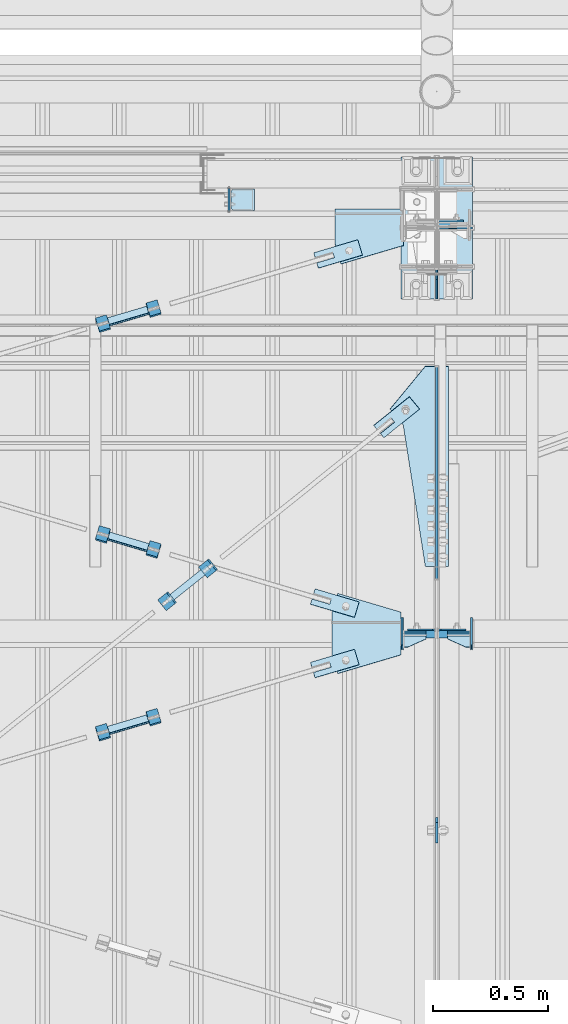
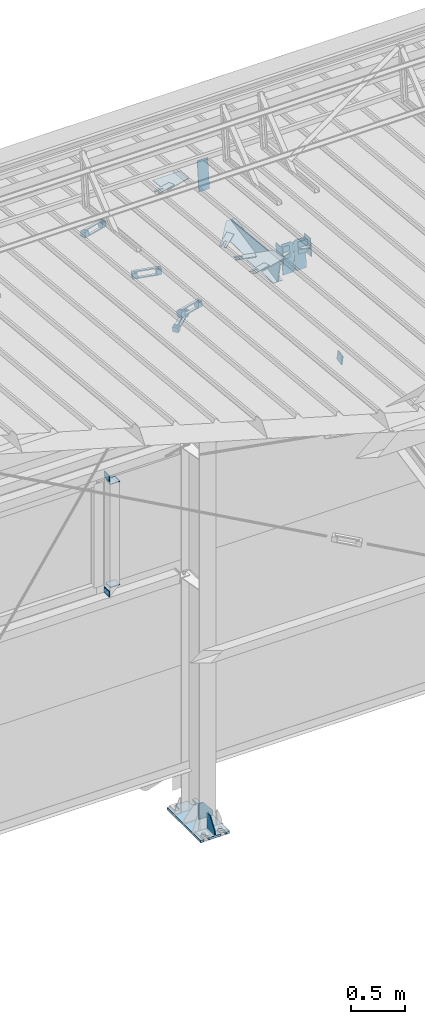
# One storey, part 164 of 709: 41 plates, 7 openings, 17 elements without a shape of their own.
"""IFC4 building model written with IfcOpenShell, lengths in millimetres."""

from ifc_helpers import new_model, si_unit, direction, frame, origin_with_axes, place, context, subcontext, project, spatial, line, arc, indexed_curve, outline, extrude, material, element, aggregate, save


model = new_model("IFC4")

# Units and contexts
model_context = context("Model", 3, precision=0.2, world=origin_with_axes(), true_north=direction((0.0, 1.0)))
body_context = subcontext(model_context, "Body", "Model", "MODEL_VIEW")
ifc_project = project(units=[si_unit("LENGTHUNIT", "METRE", prefix="MILLI"), si_unit("AREAUNIT", "SQUARE_METRE"), si_unit("VOLUMEUNIT", "CUBIC_METRE"), si_unit("MASSUNIT", "GRAM", prefix="KILO"), si_unit("TIMEUNIT", "SECOND"), si_unit("PLANEANGLEUNIT", "RADIAN"), si_unit("SOLIDANGLEUNIT", "STERADIAN"), si_unit("THERMODYNAMICTEMPERATUREUNIT", "DEGREE_CELSIUS"), si_unit("LUMINOUSINTENSITYUNIT", "LUMEN")], contexts=[model_context])

# Site, building, storey
site_placement = place(None, origin_with_axes())
site = spatial("IfcSite", under=ifc_project, at=site_placement, CompositionType="ELEMENT")
building_placement = place(site_placement, origin_with_axes())
building = spatial("IfcBuilding", under=site, at=building_placement, Name="Undefined", CompositionType="ELEMENT")
storey_placement = place(building_placement, origin_with_axes())
storey = spatial("IfcBuildingStorey", under=building, at=storey_placement, Name="Undefined", CompositionType="ELEMENT", Elevation=0.0)

# Assembly, plates, voiding features
assembly_1_placement = place(storey_placement, frame((46000.0, 21827.0, -200.0), z_axis=(-1.0, 0.0, 0.0), x_axis=(0.0, 0.0, 1.0)))
assembly_1 = element("IfcElementAssembly", 1, at=assembly_1_placement, inside=storey)
ifc_material_1 = material(Name="C355-6", Category="STEEL")
plate_1_placement = place(assembly_1_placement, frame((7434.21546, 30.02526, -3.0), z_axis=(-0.099503719, 0.9950371902, 0.0), x_axis=(0.0, 0.0, -1.0)))
plate_1 = element("IfcPlate", 2, at=plate_1_placement, material=ifc_material_1, ObjectType="581", context=body_context, shape_type="SolidModel", body=[
    extrude(outline(indexed_curve([(0.0, 0.0), (114.0, 0.0), (114.0, 333.33554), (0.0, 333.33554)], segments=[line(1, 2, 3, 4, 1)])), frame((0.0, 0.0, 4.0), z_axis=(0.0, 0.0, 1.0), x_axis=(1.0, 0.0, 0.0)), (0.0, 0.0, -1.0), 8.0),
])
plate_2_placement = place(assembly_1_placement, frame((25.0, 0.0, -3.0), z_axis=(0.0, -1.0, 0.0), x_axis=(0.0, 0.0, -1.0)))
plate_2 = element("IfcPlate", 3, at=plate_2_placement, material=ifc_material_1, ObjectType="417", context=body_context, shape_type="SolidModel", body=[
    extrude(outline(indexed_curve([(0.0, 0.0), (152.0, 0.0), (152.0, 50.0), (50.0, 175.0), (0.0, 175.0)], segments=[line(1, 2, 3, 4, 5, 1)])), frame((0.0, 0.0, 4.0), z_axis=(0.0, 0.0, 1.0), x_axis=(1.0, 0.0, 0.0)), (0.0, 0.0, -1.0), 8.0),
])
plate_3_placement = place(assembly_1_placement, frame((12.5, -308.0, 155.0), z_axis=(1.0, 0.0, 0.0), x_axis=(0.0, 0.0, -1.0)))
plate_3 = element("IfcPlate", 4, at=plate_3_placement, material=ifc_material_1, ObjectType="416", context=body_context, shape_type="SolidModel", body=[
    extrude(outline(indexed_curve([(0.0, 0.0), (310.0, 0.0), (310.0, 616.0), (0.0, 616.0)], segments=[line(1, 2, 3, 4, 1)])), frame((0.0, 0.0, 12.5), z_axis=(0.0, 0.0, 1.0), x_axis=(1.0, 0.0, 0.0)), (0.0, 0.0, -1.0), 25.0),
])
voiding_feature_1_placement = place(plate_3_placement, frame((40.0, 616.0, 0.0), z_axis=(0.0, 0.0, -1.0), x_axis=(1.0, 0.0, 0.0)))
element("IfcVoidingFeature", 5, at=voiding_feature_1_placement, cuts=plate_3, PredefinedType="HOLE", context=body_context, shape_type="SolidModel", body=[
    extrude(outline(indexed_curve([(0.0, 0.0), (50.0, 0.0), (50.0, 60.0), (42.67767, 77.67767), (25.0, 85.0), (25.0, 85.0), (7.32233, 77.67767), (0.0, 60.0)], segments=[line(1, 2, 3), arc(3, 4, 5), line(5, 6), arc(6, 7, 8), line(8, 1)])), frame((0.0, 0.0, 12.5), z_axis=(0.0, 0.0, 1.0), x_axis=(1.0, 0.0, 0.0)), (0.0, 0.0, -1.0), 25.0),
])
voiding_feature_2_placement = place(plate_3_placement, frame((40.0, 0.0, 0.0), z_axis=(0.0, 0.0, 1.0), x_axis=(1.0, 0.0, 0.0)))
element("IfcVoidingFeature", 6, at=voiding_feature_2_placement, cuts=plate_3, PredefinedType="HOLE", context=body_context, shape_type="SolidModel", body=[
    extrude(outline(indexed_curve([(0.0, 0.0), (50.0, 0.0), (50.0, 60.0), (42.67767, 77.67767), (25.0, 85.0), (25.0, 85.0), (7.32233, 77.67767), (0.0, 60.0)], segments=[line(1, 2, 3), arc(3, 4, 5), line(5, 6), arc(6, 7, 8), line(8, 1)])), frame((0.0, 0.0, 12.5), z_axis=(0.0, 0.0, 1.0), x_axis=(1.0, 0.0, 0.0)), (0.0, 0.0, -1.0), 25.0),
])
voiding_feature_3_placement = place(plate_3_placement, frame((270.0, 616.0, 0.0), z_axis=(0.0, 0.0, 1.0), x_axis=(-1.0, 0.0, 0.0)))
element("IfcVoidingFeature", 7, at=voiding_feature_3_placement, cuts=plate_3, PredefinedType="HOLE", context=body_context, shape_type="SolidModel", body=[
    extrude(outline(indexed_curve([(0.0, 0.0), (50.0, 0.0), (50.0, 60.0), (42.67767, 77.67767), (25.0, 85.0), (25.0, 85.0), (7.32233, 77.67767), (0.0, 60.0)], segments=[line(1, 2, 3), arc(3, 4, 5), line(5, 6), arc(6, 7, 8), line(8, 1)])), frame((0.0, 0.0, 12.5), z_axis=(0.0, 0.0, 1.0), x_axis=(1.0, 0.0, 0.0)), (0.0, 0.0, -1.0), 25.0),
])
voiding_feature_4_placement = place(plate_3_placement, frame((270.0, 0.0, 0.0), z_axis=(0.0, 0.0, -1.0), x_axis=(-1.0, 0.0, 0.0)))
element("IfcVoidingFeature", 8, at=voiding_feature_4_placement, cuts=plate_3, PredefinedType="HOLE", context=body_context, shape_type="SolidModel", body=[
    extrude(outline(indexed_curve([(0.0, 0.0), (50.0, 0.0), (50.0, 60.0), (42.67767, 77.67767), (25.0, 85.0), (25.0, 85.0), (7.32233, 77.67767), (0.0, 60.0)], segments=[line(1, 2, 3), arc(3, 4, 5), line(5, 6), arc(6, 7, 8), line(8, 1)])), frame((0.0, 0.0, 12.5), z_axis=(0.0, 0.0, 1.0), x_axis=(1.0, 0.0, 0.0)), (0.0, 0.0, -1.0), 25.0),
])
plate_4_placement = place(assembly_1_placement, frame((25.0, -173.0, 0.0), z_axis=(0.0, 0.0, 1.0), x_axis=(0.0, -1.0, 0.0)))
plate_4 = element("IfcPlate", 9, at=plate_4_placement, material=ifc_material_1, ObjectType="418", context=body_context, shape_type="SolidModel", body=[
    extrude(outline(indexed_curve([(0.0, 0.0), (135.0, 0.0), (135.0, 50.0), (50.0, 175.0), (0.0, 175.0)], segments=[line(1, 2, 3, 4, 5, 1)])), frame((0.0, 0.0, 4.0), z_axis=(0.0, 0.0, 1.0), x_axis=(1.0, 0.0, 0.0)), (0.0, 0.0, -1.0), 8.0),
])
aggregate(assembly_1, [plate_1, plate_2, plate_3, plate_4])

# Assembly, plates
assembly_2_placement = place(storey_placement, frame((46000.0, 21654.0, 7089.70002), z_axis=(-1.0, 0.0, 0.0), x_axis=(0.0, -0.9950371902, 0.099503719)))
assembly_2 = element("IfcElementAssembly", 10, at=assembly_2_placement, inside=storey)
plate_5_placement = place(assembly_2_placement, frame((1597.88359, 163.0, -127.0), z_axis=(1.0, 0.0, 0.0), x_axis=(0.0, 0.0, 1.0)))
plate_5 = element("IfcPlate", 11, at=plate_5_placement, material=ifc_material_1, ObjectType="585", context=body_context, shape_type="SolidModel", body=[
    extrude(outline(indexed_curve([(0.0, 0.0), (108.0, 0.0), (123.0, 15.0), (123.0, 311.0), (108.0, 326.0), (0.0, 326.0)], segments=[line(1, 2, 3, 4, 5, 6, 1)])), frame((0.0, 0.0, 4.0), z_axis=(0.0, 0.0, 1.0), x_axis=(1.0, 0.0, 0.0)), (0.0, 0.0, -1.0), 8.0),
])
plate_6_placement = place(assembly_2_placement, frame((1597.88359, 163.0, 127.0), z_axis=(-1.0, 0.0, 0.0), x_axis=(0.0, 0.0, -1.0)))
plate_6 = element("IfcPlate", 12, at=plate_6_placement, material=ifc_material_1, ObjectType="585", context=body_context, shape_type="SolidModel", body=[
    extrude(outline(indexed_curve([(0.0, 0.0), (108.0, 0.0), (123.0, 15.0), (123.0, 311.0), (108.0, 326.0), (0.0, 326.0)], segments=[line(1, 2, 3, 4, 5, 6, 1)])), frame((0.0, 0.0, 4.0), z_axis=(0.0, 0.0, 1.0), x_axis=(1.0, 0.0, 0.0)), (0.0, 0.0, -1.0), 8.0),
])
plate_7_placement = place(assembly_2_placement, frame((1261.40018, -436.65536, -50.0), z_axis=(0.2927142719, 0.9561999556, 0.0), x_axis=(-0.9561999556, 0.2927142719, 0.0)))
plate_7 = element("IfcPlate", 13, at=plate_7_placement, material=ifc_material_1, ObjectType="489", context=body_context, shape_type="SolidModel", body=[
    extrude(outline(indexed_curve([(0.0, 0.0), (887.65935, 0.0), (887.65935, 100.0), (698.2863, 253.1922), (628.6057, 196.23068), (0.0, 100.0)], segments=[line(1, 2, 3, 4, 5, 6, 1)])), frame((0.0, 0.0, 4.0), z_axis=(0.0, 0.0, 1.0), x_axis=(1.0, 0.0, 0.0)), (0.0, 0.0, -1.0), 8.0),
])
plate_8_placement = place(assembly_2_placement, frame((1342.111, -173.0, 0.0), z_axis=(0.0, 0.0, 1.0), x_axis=(-1.0, 0.0, 0.0)))
plate_8 = element("IfcPlate", 14, at=plate_8_placement, material=ifc_material_1, ObjectType="449", context=body_context, shape_type="SolidModel", body=[
    extrude(outline(indexed_curve([(0.0, 0.0), (928.3198, 0.0), (79.53997, 259.83056)], segments=[line(1, 2, 3, 1)])), frame((0.0, 0.0, 6.0), z_axis=(0.0, 0.0, 1.0), x_axis=(1.0, 0.0, 0.0)), (0.0, 0.0, -1.0), 12.0),
])
aggregate(assembly_2, [plate_5, plate_6, plate_7, plate_8])

# Assembly, plate
assembly_3_placement = place(storey_placement, frame((44916.07962, 20275.59044, 6772.92001), z_axis=(0.625451877, -0.7802627439, 1e-10), x_axis=(0.7742288439, 0.6206151549, 0.124123031)))
assembly_3 = element("IfcElementAssembly", 15, at=assembly_3_placement, inside=storey)
plate_9_placement = place(assembly_3_placement, frame((1074.34134, 5.35577, -34.5878), z_axis=(0.0, -0.9882227648, -0.1530221131), x_axis=(1.0, 0.0, 0.0)))
plate_9 = element("IfcPlate", 16, at=plate_9_placement, material=ifc_material_1, ObjectType="490", context=body_context, shape_type="SolidModel", body=[
    extrude(outline(indexed_curve([(0.0, 0.0), (200.0, 0.0), (200.0, 70.0), (0.0, 70.0), (0.0, 46.0), (80.0, 46.0), (80.0, 24.0), (0.0, 24.0)], segments=[line(1, 2, 3, 4, 5, 6, 7, 8, 1)])), frame((0.0, 0.0, 4.0), z_axis=(0.0, 0.0, 1.0), x_axis=(1.0, 0.0, 0.0)), (0.0, 0.0, -1.0), 8.0),
])
aggregate(assembly_3, [plate_9])

# Assembly, plates
assembly_4_placement = place(storey_placement, frame((45020.97403, 20321.22431, 6816.96217), z_axis=(-0.7742288439, -0.6206151548, -0.1241230313), x_axis=(-0.625451877, 0.780262744, 0.0)))
assembly_4 = element("IfcElementAssembly", 17, at=assembly_4_placement, inside=storey)
ifc_material_2 = material(Name="Steel_Undefined", Category="STEEL")
plate_10_placement = place(assembly_4_placement, frame((15.0, 66.0, 230.0), z_axis=(0.0, 1.0, 0.0), x_axis=(1.0, 0.0, 0.0)))
plate_10 = element("IfcPlate", 18, at=plate_10_placement, material=ifc_material_2, ObjectType="484", context=body_context, shape_type="SolidModel", body=[
    extrude(outline(indexed_curve([(0.0, 0.0), (30.0, 0.0), (30.0, 230.0), (0.0, 230.0)], segments=[line(1, 2, 3, 4, 1)])), frame((0.0, 0.0, 6.0), z_axis=(0.0, 0.0, 1.0), x_axis=(1.0, 0.0, 0.0)), (0.0, 0.0, -1.0), 12.0),
])
plate_11_placement = place(assembly_4_placement, origin_with_axes())
plate_11 = element("IfcPlate", 19, at=plate_11_placement, material=ifc_material_2, ObjectType="482", context=body_context, shape_type="SolidModel", body=[
    extrude(outline(indexed_curve([(0.0, 0.0), (60.0, 0.0), (60.0, 60.0), (0.0, 60.0)], segments=[line(1, 2, 3, 4, 1)])), frame((0.0, 0.0, 25.0), z_axis=(0.0, 0.0, 1.0), x_axis=(1.0, 0.0, 0.0)), (0.0, 0.0, -1.0), 50.0),
])
plate_12_placement = place(assembly_4_placement, frame((0.0, 0.0, 230.0), z_axis=(0.0, 0.0, 1.0), x_axis=(1.0, 0.0, 0.0)))
plate_12 = element("IfcPlate", 20, at=plate_12_placement, material=ifc_material_2, ObjectType="483", context=body_context, shape_type="SolidModel", body=[
    extrude(outline(indexed_curve([(0.0, 0.0), (60.0, 0.0), (60.0, 60.0), (0.0, 60.0)], segments=[line(1, 2, 3, 4, 1)])), frame((0.0, 0.0, 25.0), z_axis=(0.0, 0.0, 1.0), x_axis=(1.0, 0.0, 0.0)), (0.0, 0.0, -1.0), 50.0),
])
plate_13_placement = place(assembly_4_placement, frame((15.0, -6.0, 230.0), z_axis=(0.0, 1.0, 0.0), x_axis=(1.0, 0.0, 0.0)))
plate_13 = element("IfcPlate", 21, at=plate_13_placement, material=ifc_material_2, ObjectType="484", context=body_context, shape_type="SolidModel", body=[
    extrude(outline(indexed_curve([(0.0, 0.0), (30.0, 0.0), (30.0, 230.0), (0.0, 230.0)], segments=[line(1, 2, 3, 4, 1)])), frame((0.0, 0.0, 6.0), z_axis=(0.0, 0.0, 1.0), x_axis=(1.0, 0.0, 0.0)), (0.0, 0.0, -1.0), 12.0),
])
aggregate(assembly_4, [plate_10, plate_11, plate_12, plate_13])

# Assembly, plate
assembly_5_placement = place(storey_placement, frame((46000.0, 19241.53388, 6684.40595), z_axis=(1.0, 0.0, 0.0), x_axis=(0.0, -0.9805806757, -0.1961161349)))
assembly_5 = element("IfcElementAssembly", 22, at=assembly_5_placement, inside=storey)
plate_14_placement = place(assembly_5_placement, origin_with_axes())
plate_14 = element("IfcPlate", 23, at=plate_14_placement, material=ifc_material_1, ObjectType="491", context=body_context, shape_type="SolidModel", body=[
    extrude(outline(indexed_curve([(0.0, 0.0), (90.0, 0.0), (90.0, 110.0), (0.0, 110.0)], segments=[line(1, 2, 3, 4, 1)])), frame((0.0, 0.0, 6.0), z_axis=(0.0, 0.0, 1.0), x_axis=(1.0, 0.0, 0.0)), (0.0, 0.0, -1.0), 12.0),
])
aggregate(assembly_5, [plate_14])

assembly_6_placement = place(storey_placement, frame((46000.0, 21950.0, 2550.0), z_axis=(0.0, 0.0, -1.0), x_axis=(-1.0, 0.0, 0.0)))
assembly_6 = element("IfcElementAssembly", 24, at=assembly_6_placement, inside=storey)
plate_15_placement = place(assembly_6_placement, frame((904.0, 50.0, -50.0), z_axis=(-1.0, 0.0, 0.0), x_axis=(0.0, 0.0, -1.0)))
plate_15 = element("IfcPlate", 25, at=plate_15_placement, material=ifc_material_1, ObjectType="509", context=body_context, shape_type="SolidModel", body=[
    extrude(outline(indexed_curve([(0.0, 0.0), (65.0, 0.0), (65.0, 100.0), (0.0, 100.0)], segments=[line(1, 2, 3, 4, 1)])), frame((0.0, 0.0, 4.0), z_axis=(0.0, 0.0, 1.0), x_axis=(1.0, 0.0, 0.0)), (0.0, 0.0, -1.0), 8.0),
])
aggregate(assembly_6, [plate_15])

assembly_7_placement = place(storey_placement, frame((46000.0, 21950.0, 4020.0), z_axis=(0.0, 0.0, -1.0), x_axis=(-1.0, 0.0, 0.0)))
assembly_7 = element("IfcElementAssembly", 26, at=assembly_7_placement, inside=storey)
plate_16_placement = place(assembly_7_placement, frame((904.0, -50.0, 50.0), z_axis=(-1.0, 0.0, 0.0), x_axis=(0.0, 0.0, 1.0)))
plate_16 = element("IfcPlate", 27, at=plate_16_placement, material=ifc_material_1, ObjectType="509", context=body_context, shape_type="SolidModel", body=[
    extrude(outline(indexed_curve([(0.0, 0.0), (65.0, 0.0), (65.0, 100.0), (0.0, 100.0)], segments=[line(1, 2, 3, 4, 1)])), frame((0.0, 0.0, 4.0), z_axis=(0.0, 0.0, 1.0), x_axis=(1.0, 0.0, 0.0)), (0.0, 0.0, -1.0), 8.0),
])
aggregate(assembly_7, [plate_16])

# Assembly, plates
assembly_8_placement = place(storey_placement, frame((45150.0, 21950.0, 2600.0), z_axis=(-1.0, 0.0, 0.0), x_axis=(0.0, 0.0, 1.0)))
assembly_8 = element("IfcElementAssembly", 28, at=assembly_8_placement, inside=storey)
plate_17_placement = place(assembly_8_placement, frame((103.0, -46.0, 46.0), z_axis=(-1.0, 0.0, 0.0), x_axis=(0.0, 1.0, 0.0)))
plate_17 = element("IfcPlate", 29, at=plate_17_placement, material=ifc_material_1, ObjectType="510", context=body_context, shape_type="SolidModel", body=[
    extrude(outline(indexed_curve([(0.0, 10.0), (10.0, 0.0), (82.0, 0.0), (92.0, 10.0), (92.0, 104.0), (0.0, 104.0)], segments=[line(1, 2, 3, 4, 5, 6, 1)])), frame((0.0, 0.0, 4.0), z_axis=(0.0, 0.0, 1.0), x_axis=(1.0, 0.0, 0.0)), (0.0, 0.0, -1.0), 8.0),
])
plate_18_placement = place(assembly_8_placement, frame((1267.0, 46.0, 46.0), z_axis=(1.0, 0.0, 0.0), x_axis=(0.0, -1.0, 0.0)))
plate_18 = element("IfcPlate", 30, at=plate_18_placement, material=ifc_material_1, ObjectType="510", context=body_context, shape_type="SolidModel", body=[
    extrude(outline(indexed_curve([(0.0, 10.0), (10.0, 0.0), (82.0, 0.0), (92.0, 10.0), (92.0, 104.0), (0.0, 104.0)], segments=[line(1, 2, 3, 4, 5, 6, 1)])), frame((0.0, 0.0, 4.0), z_axis=(0.0, 0.0, 1.0), x_axis=(1.0, 0.0, 0.0)), (0.0, 0.0, -1.0), 8.0),
])
aggregate(assembly_8, [plate_17, plate_18])

# Assembly, plate, voiding feature
assembly_9_placement = place(storey_placement, frame((44658.15773, 19666.8041, 7369.82361), z_axis=(0.2852311229, -0.9537021177, 0.0953702118), x_axis=(0.9584587662, 0.2838155751, -0.028381558)))
assembly_9 = element("IfcElementAssembly", 31, at=assembly_9_placement, inside=storey)
plate_19_placement = place(assembly_9_placement, frame((1036.9749, 0.0, 35.0), z_axis=(0.0, 1.0, 0.0), x_axis=(0.0, 0.0, -1.0)))
plate_19 = element("IfcPlate", 32, at=plate_19_placement, material=ifc_material_1, ObjectType="574", context=body_context, shape_type="SolidModel", body=[
    extrude(outline(indexed_curve([(0.0, 0.0), (70.0, 0.0), (70.0, 200.0), (0.0, 200.0)], segments=[line(1, 2, 3, 4, 1)])), frame((0.0, 0.0, 4.0), z_axis=(0.0, 0.0, 1.0), x_axis=(1.0, 0.0, 0.0)), (0.0, 0.0, -1.0), 8.0),
])
voiding_feature_5_placement = place(plate_19_placement, frame((24.0, 120.0, 0.0), z_axis=(0.0, 0.0, 1.0), x_axis=(1.0, 0.0, 0.0)))
element("IfcVoidingFeature", 33, at=voiding_feature_5_placement, cuts=plate_19, Name="PLATE", PredefinedType="HOLE", context=body_context, shape_type="SolidModel", body=[
    extrude(outline(indexed_curve([(0.0, 0.0), (22.0, 0.0), (22.0, 85.0), (0.0, 85.0)], segments=[line(1, 2, 3, 4, 1)])), frame((0.0, 0.0, 6.5), z_axis=(0.0, 0.0, 1.0), x_axis=(1.0, 0.0, 0.0)), (0.0, 0.0, -1.0), 13.0),
])
aggregate(assembly_9, [plate_19])

# Assembly, plates
assembly_10_placement = place(storey_placement, frame((44776.93742, 19673.81694, 7399.27195), z_axis=(-0.9584587662, -0.2838155751, 0.0283815575), x_axis=(-0.2852311229, 0.9537021176, -0.095370212)))
assembly_10 = element("IfcElementAssembly", 34, at=assembly_10_placement, inside=storey)
plate_20_placement = place(assembly_10_placement, frame((15.0, -6.0, 230.0), z_axis=(0.0, 1.0, 0.0), x_axis=(1.0, 0.0, 0.0)))
plate_20 = element("IfcPlate", 35, at=plate_20_placement, material=ifc_material_2, ObjectType="484", context=body_context, shape_type="SolidModel", body=[
    extrude(outline(indexed_curve([(0.0, 0.0), (30.0, 0.0), (30.0, 230.0), (0.0, 230.0)], segments=[line(1, 2, 3, 4, 1)])), frame((0.0, 0.0, 6.0), z_axis=(0.0, 0.0, 1.0), x_axis=(1.0, 0.0, 0.0)), (0.0, 0.0, -1.0), 12.0),
])
plate_21_placement = place(assembly_10_placement, frame((15.0, 66.0, 230.0), z_axis=(0.0, 1.0, 0.0), x_axis=(1.0, 0.0, 0.0)))
plate_21 = element("IfcPlate", 36, at=plate_21_placement, material=ifc_material_2, ObjectType="484", context=body_context, shape_type="SolidModel", body=[
    extrude(outline(indexed_curve([(0.0, 0.0), (30.0, 0.0), (30.0, 230.0), (0.0, 230.0)], segments=[line(1, 2, 3, 4, 1)])), frame((0.0, 0.0, 6.0), z_axis=(0.0, 0.0, 1.0), x_axis=(1.0, 0.0, 0.0)), (0.0, 0.0, -1.0), 12.0),
])
plate_22_placement = place(assembly_10_placement, frame((0.0, 0.0, 230.0), z_axis=(0.0, 0.0, 1.0), x_axis=(1.0, 0.0, 0.0)))
plate_22 = element("IfcPlate", 37, at=plate_22_placement, material=ifc_material_2, ObjectType="483", context=body_context, shape_type="SolidModel", body=[
    extrude(outline(indexed_curve([(0.0, 0.0), (60.0, 0.0), (60.0, 60.0), (0.0, 60.0)], segments=[line(1, 2, 3, 4, 1)])), frame((0.0, 0.0, 25.0), z_axis=(0.0, 0.0, 1.0), x_axis=(1.0, 0.0, 0.0)), (0.0, 0.0, -1.0), 50.0),
])
plate_23_placement = place(assembly_10_placement, origin_with_axes())
plate_23 = element("IfcPlate", 38, at=plate_23_placement, material=ifc_material_2, ObjectType="482", context=body_context, shape_type="SolidModel", body=[
    extrude(outline(indexed_curve([(0.0, 0.0), (60.0, 0.0), (60.0, 60.0), (0.0, 60.0)], segments=[line(1, 2, 3, 4, 1)])), frame((0.0, 0.0, 25.0), z_axis=(0.0, 0.0, 1.0), x_axis=(1.0, 0.0, 0.0)), (0.0, 0.0, -1.0), 50.0),
])
aggregate(assembly_10, [plate_20, plate_21, plate_22, plate_23])

# Assembly, plate, voiding feature
assembly_11_placement = place(storey_placement, frame((44658.15773, 21443.50385, 7192.15363), z_axis=(0.2852311229, -0.9537021177, 0.0953702118), x_axis=(0.9584587662, 0.2838155751, -0.028381558)))
assembly_11 = element("IfcElementAssembly", 39, at=assembly_11_placement, inside=storey)
plate_24_placement = place(assembly_11_placement, frame((1051.9749, 0.0, 35.0), z_axis=(0.0, 1.0, 0.0), x_axis=(0.0, 0.0, -1.0)))
plate_24 = element("IfcPlate", 40, at=plate_24_placement, material=ifc_material_1, ObjectType="574", context=body_context, shape_type="SolidModel", body=[
    extrude(outline(indexed_curve([(0.0, 0.0), (70.0, 0.0), (70.0, 200.0), (0.0, 200.0)], segments=[line(1, 2, 3, 4, 1)])), frame((0.0, 0.0, 4.0), z_axis=(0.0, 0.0, 1.0), x_axis=(1.0, 0.0, 0.0)), (0.0, 0.0, -1.0), 8.0),
])
voiding_feature_6_placement = place(plate_24_placement, frame((24.0, 120.0, 0.0), z_axis=(0.0, 0.0, 1.0), x_axis=(1.0, 0.0, 0.0)))
element("IfcVoidingFeature", 41, at=voiding_feature_6_placement, cuts=plate_24, Name="PLATE", PredefinedType="HOLE", context=body_context, shape_type="SolidModel", body=[
    extrude(outline(indexed_curve([(0.0, 0.0), (22.0, 0.0), (22.0, 85.0), (0.0, 85.0)], segments=[line(1, 2, 3, 4, 1)])), frame((0.0, 0.0, 6.5), z_axis=(0.0, 0.0, 1.0), x_axis=(1.0, 0.0, 0.0)), (0.0, 0.0, -1.0), 13.0),
])
aggregate(assembly_11, [plate_24])

# Assembly, plates
assembly_12_placement = place(storey_placement, frame((44776.93742, 21450.51669, 7221.60197), z_axis=(-0.9584587662, -0.2838155751, 0.0283815575), x_axis=(-0.2852311229, 0.9537021176, -0.095370212)))
assembly_12 = element("IfcElementAssembly", 42, at=assembly_12_placement, inside=storey)
plate_25_placement = place(assembly_12_placement, origin_with_axes())
plate_25 = element("IfcPlate", 43, at=plate_25_placement, material=ifc_material_2, ObjectType="482", context=body_context, shape_type="SolidModel", body=[
    extrude(outline(indexed_curve([(0.0, 0.0), (60.0, 0.0), (60.0, 60.0), (0.0, 60.0)], segments=[line(1, 2, 3, 4, 1)])), frame((0.0, 0.0, 25.0), z_axis=(0.0, 0.0, 1.0), x_axis=(1.0, 0.0, 0.0)), (0.0, 0.0, -1.0), 50.0),
])
plate_26_placement = place(assembly_12_placement, frame((0.0, 0.0, 230.0), z_axis=(0.0, 0.0, 1.0), x_axis=(1.0, 0.0, 0.0)))
plate_26 = element("IfcPlate", 44, at=plate_26_placement, material=ifc_material_2, ObjectType="483", context=body_context, shape_type="SolidModel", body=[
    extrude(outline(indexed_curve([(0.0, 0.0), (60.0, 0.0), (60.0, 60.0), (0.0, 60.0)], segments=[line(1, 2, 3, 4, 1)])), frame((0.0, 0.0, 25.0), z_axis=(0.0, 0.0, 1.0), x_axis=(1.0, 0.0, 0.0)), (0.0, 0.0, -1.0), 50.0),
])
plate_27_placement = place(assembly_12_placement, frame((15.0, 66.0, 230.0), z_axis=(0.0, 1.0, 0.0), x_axis=(1.0, 0.0, 0.0)))
plate_27 = element("IfcPlate", 45, at=plate_27_placement, material=ifc_material_2, ObjectType="484", context=body_context, shape_type="SolidModel", body=[
    extrude(outline(indexed_curve([(0.0, 0.0), (30.0, 0.0), (30.0, 230.0), (0.0, 230.0)], segments=[line(1, 2, 3, 4, 1)])), frame((0.0, 0.0, 6.0), z_axis=(0.0, 0.0, 1.0), x_axis=(1.0, 0.0, 0.0)), (0.0, 0.0, -1.0), 12.0),
])
plate_28_placement = place(assembly_12_placement, frame((15.0, -6.0, 230.0), z_axis=(0.0, 1.0, 0.0), x_axis=(1.0, 0.0, 0.0)))
plate_28 = element("IfcPlate", 46, at=plate_28_placement, material=ifc_material_2, ObjectType="484", context=body_context, shape_type="SolidModel", body=[
    extrude(outline(indexed_curve([(0.0, 0.0), (30.0, 0.0), (30.0, 230.0), (0.0, 230.0)], segments=[line(1, 2, 3, 4, 1)])), frame((0.0, 0.0, 6.0), z_axis=(0.0, 0.0, 1.0), x_axis=(1.0, 0.0, 0.0)), (0.0, 0.0, -1.0), 12.0),
])
aggregate(assembly_12, [plate_25, plate_26, plate_27, plate_28])

# Assembly, plate, voiding feature
assembly_13_placement = place(storey_placement, frame((44658.15773, 20461.48771, 7290.35524), z_axis=(-0.2852311229, -0.9537021177, 0.0953702118), x_axis=(0.9584587662, -0.2838155751, 0.028381558)))
assembly_13 = element("IfcElementAssembly", 47, at=assembly_13_placement, inside=storey)
plate_29_placement = place(assembly_13_placement, frame((1036.9749, 0.0, 35.0), z_axis=(0.0, 1.0, 0.0), x_axis=(0.0, 0.0, -1.0)))
plate_29 = element("IfcPlate", 48, at=plate_29_placement, material=ifc_material_1, ObjectType="574", context=body_context, shape_type="SolidModel", body=[
    extrude(outline(indexed_curve([(0.0, 0.0), (70.0, 0.0), (70.0, 200.0), (0.0, 200.0)], segments=[line(1, 2, 3, 4, 1)])), frame((0.0, 0.0, 4.0), z_axis=(0.0, 0.0, 1.0), x_axis=(1.0, 0.0, 0.0)), (0.0, 0.0, -1.0), 8.0),
])
voiding_feature_7_placement = place(plate_29_placement, frame((24.0, 120.0, 0.0), z_axis=(0.0, 0.0, 1.0), x_axis=(1.0, 0.0, 0.0)))
element("IfcVoidingFeature", 49, at=voiding_feature_7_placement, cuts=plate_29, Name="PLATE", PredefinedType="HOLE", context=body_context, shape_type="SolidModel", body=[
    extrude(outline(indexed_curve([(0.0, 0.0), (22.0, 0.0), (22.0, 85.0), (0.0, 85.0)], segments=[line(1, 2, 3, 4, 1)])), frame((0.0, 0.0, 6.5), z_axis=(0.0, 0.0, 1.0), x_axis=(1.0, 0.0, 0.0)), (0.0, 0.0, -1.0), 13.0),
])
aggregate(assembly_13, [plate_29])

# Assembly, plates
assembly_14_placement = place(storey_placement, frame((44759.82355, 20403.22297, 7326.33135), z_axis=(-0.9584587662, 0.2838155751, -0.0283815575), x_axis=(0.2852311229, 0.9537021176, -0.095370212)))
assembly_14 = element("IfcElementAssembly", 50, at=assembly_14_placement, inside=storey)
plate_30_placement = place(assembly_14_placement, origin_with_axes())
plate_30 = element("IfcPlate", 51, at=plate_30_placement, material=ifc_material_2, ObjectType="482", context=body_context, shape_type="SolidModel", body=[
    extrude(outline(indexed_curve([(0.0, 0.0), (60.0, 0.0), (60.0, 60.0), (0.0, 60.0)], segments=[line(1, 2, 3, 4, 1)])), frame((0.0, 0.0, 25.0), z_axis=(0.0, 0.0, 1.0), x_axis=(1.0, 0.0, 0.0)), (0.0, 0.0, -1.0), 50.0),
])
plate_31_placement = place(assembly_14_placement, frame((0.0, 0.0, 230.0), z_axis=(0.0, 0.0, 1.0), x_axis=(1.0, 0.0, 0.0)))
plate_31 = element("IfcPlate", 52, at=plate_31_placement, material=ifc_material_2, ObjectType="483", context=body_context, shape_type="SolidModel", body=[
    extrude(outline(indexed_curve([(0.0, 0.0), (60.0, 0.0), (60.0, 60.0), (0.0, 60.0)], segments=[line(1, 2, 3, 4, 1)])), frame((0.0, 0.0, 25.0), z_axis=(0.0, 0.0, 1.0), x_axis=(1.0, 0.0, 0.0)), (0.0, 0.0, -1.0), 50.0),
])
plate_32_placement = place(assembly_14_placement, frame((15.0, 66.0, 230.0), z_axis=(0.0, 1.0, 0.0), x_axis=(1.0, 0.0, 0.0)))
plate_32 = element("IfcPlate", 53, at=plate_32_placement, material=ifc_material_2, ObjectType="484", context=body_context, shape_type="SolidModel", body=[
    extrude(outline(indexed_curve([(0.0, 0.0), (30.0, 0.0), (30.0, 230.0), (0.0, 230.0)], segments=[line(1, 2, 3, 4, 1)])), frame((0.0, 0.0, 6.0), z_axis=(0.0, 0.0, 1.0), x_axis=(1.0, 0.0, 0.0)), (0.0, 0.0, -1.0), 12.0),
])
plate_33_placement = place(assembly_14_placement, frame((15.0, -6.0, 230.0), z_axis=(0.0, 1.0, 0.0), x_axis=(1.0, 0.0, 0.0)))
plate_33 = element("IfcPlate", 54, at=plate_33_placement, material=ifc_material_2, ObjectType="484", context=body_context, shape_type="SolidModel", body=[
    extrude(outline(indexed_curve([(0.0, 0.0), (30.0, 0.0), (30.0, 230.0), (0.0, 230.0)], segments=[line(1, 2, 3, 4, 1)])), frame((0.0, 0.0, 6.0), z_axis=(0.0, 0.0, 1.0), x_axis=(1.0, 0.0, 0.0)), (0.0, 0.0, -1.0), 12.0),
])
aggregate(assembly_14, [plate_30, plate_31, plate_32, plate_33])

assembly_15_placement = place(storey_placement, frame((46000.0, 20063.34988, 7322.12913), z_axis=(0.0, -0.9950371902, 0.099503719), x_axis=(-1.0, 0.0, 0.0)))
assembly_15 = element("IfcElementAssembly", 55, at=assembly_15_placement, inside=storey)
plate_34_placement = place(assembly_15_placement, frame((47.0, 0.0, 60.0), z_axis=(0.0, 1.0, 0.0), x_axis=(1.0, 0.0, 0.0)))
plate_34 = element("IfcPlate", 56, at=plate_34_placement, material=ifc_material_1, ObjectType="588", context=body_context, shape_type="SolidModel", body=[
    extrude(outline(indexed_curve([(0.0, 36.0), (80.0, 0.0), (100.0, 0.0), (100.0, 56.0), (0.0, 56.0)], segments=[line(1, 2, 3, 4, 5, 1)])), frame((0.0, 0.0, 4.0), z_axis=(0.0, 0.0, 1.0), x_axis=(1.0, 0.0, 0.0)), (0.0, 0.0, -1.0), 8.0),
])
plate_35_placement = place(assembly_15_placement, frame((151.0, -98.0, -60.0), z_axis=(-1.0, 0.0, 0.0), x_axis=(0.0, 0.0, 1.0)))
plate_35 = element("IfcPlate", 57, at=plate_35_placement, material=ifc_material_1, ObjectType="586", context=body_context, shape_type="SolidModel", body=[
    extrude(outline(indexed_curve([(0.0, 0.0), (120.0, 0.0), (120.0, 196.0), (0.0, 196.0)], segments=[line(1, 2, 3, 4, 1)])), frame((0.0, 0.0, 4.0), z_axis=(0.0, 0.0, 1.0), x_axis=(1.0, 0.0, 0.0)), (0.0, 0.0, -1.0), 8.0),
])
plate_36_placement = place(assembly_15_placement, frame((47.0, -65.0, 0.0), z_axis=(0.0, 0.0, 1.0), x_axis=(1.0, 0.0, 0.0)))
plate_36 = element("IfcPlate", 58, at=plate_36_placement, material=ifc_material_1, ObjectType="587", context=body_context, shape_type="SolidModel", body=[
    extrude(outline(indexed_curve([(0.0, 0.0), (100.0, 0.0), (100.0, 130.0), (0.0, 130.0)], segments=[line(1, 2, 3, 4, 1)])), frame((0.0, 0.0, 4.0), z_axis=(0.0, 0.0, 1.0), x_axis=(1.0, 0.0, 0.0)), (0.0, 0.0, -1.0), 8.0),
])
plate_37_placement = place(assembly_15_placement, frame((154.99945, 0.0, 93.07721), z_axis=(0.0, -1.0, 0.0), x_axis=(0.0, 0.0, -1.0)))
plate_37 = element("IfcPlate", 59, at=plate_37_placement, material=ifc_material_1, ObjectType="576", context=body_context, shape_type="SolidModel", body=[
    extrude(outline(indexed_curve([(0.0, 0.0), (186.15442, 0.0), (268.27702, 275.95562), (182.01573, 301.62642), (4.13868, 301.62642), (-82.1226, 275.95562)], segments=[line(1, 2, 3, 4, 5, 6, 1)])), frame((0.0, 0.0, 4.0), z_axis=(0.0, 0.0, 1.0), x_axis=(1.0, 0.0, 0.0)), (0.0, 0.0, -1.0), 8.0),
])
aggregate(assembly_15, [plate_34, plate_35, plate_36, plate_37])

assembly_16_placement = place(storey_placement, frame((50000.0, 20063.34988, 7322.12913), z_axis=(0.0, -0.9950371902, 0.099503719), x_axis=(-1.0, 0.0, 0.0)))
assembly_16 = element("IfcElementAssembly", 60, at=assembly_16_placement, inside=storey)
plate_38_placement = place(assembly_16_placement, frame((3953.0, 0.0, 60.0), z_axis=(0.0, -1.0, 0.0), x_axis=(-1.0, 0.0, 0.0)))
plate_38 = element("IfcPlate", 61, at=plate_38_placement, material=ifc_material_1, ObjectType="588", context=body_context, shape_type="SolidModel", body=[
    extrude(outline(indexed_curve([(0.0, 36.0), (80.0, 0.0), (100.0, 0.0), (100.0, 56.0), (0.0, 56.0)], segments=[line(1, 2, 3, 4, 5, 1)])), frame((0.0, 0.0, 4.0), z_axis=(0.0, 0.0, 1.0), x_axis=(1.0, 0.0, 0.0)), (0.0, 0.0, -1.0), 8.0),
])
plate_39_placement = place(assembly_16_placement, frame((3849.0, -98.0, 60.0), z_axis=(1.0, 0.0, 0.0), x_axis=(0.0, 0.0, -1.0)))
plate_39 = element("IfcPlate", 62, at=plate_39_placement, material=ifc_material_1, ObjectType="586", context=body_context, shape_type="SolidModel", body=[
    extrude(outline(indexed_curve([(0.0, 0.0), (120.0, 0.0), (120.0, 196.0), (0.0, 196.0)], segments=[line(1, 2, 3, 4, 1)])), frame((0.0, 0.0, 4.0), z_axis=(0.0, 0.0, 1.0), x_axis=(1.0, 0.0, 0.0)), (0.0, 0.0, -1.0), 8.0),
])
plate_40_placement = place(assembly_16_placement, frame((3953.0, 65.0, 0.0), z_axis=(0.0, 0.0, 1.0), x_axis=(-1.0, 0.0, 0.0)))
plate_40 = element("IfcPlate", 63, at=plate_40_placement, material=ifc_material_1, ObjectType="587", context=body_context, shape_type="SolidModel", body=[
    extrude(outline(indexed_curve([(0.0, 0.0), (100.0, 0.0), (100.0, 130.0), (0.0, 130.0)], segments=[line(1, 2, 3, 4, 1)])), frame((0.0, 0.0, 4.0), z_axis=(0.0, 0.0, 1.0), x_axis=(1.0, 0.0, 0.0)), (0.0, 0.0, -1.0), 8.0),
])
aggregate(assembly_16, [plate_38, plate_39, plate_40])

# Assembly, plate
assembly_17_placement = place(storey_placement, frame((46000.0, 21841.04467, 7154.40952), z_axis=(0.0, -0.9950371902, 0.099503719), x_axis=(-1.0, 0.0, 0.0)))
assembly_17 = element("IfcElementAssembly", 64, at=assembly_17_placement, inside=storey)
plate_41_placement = place(assembly_17_placement, frame((145.0, 10.0, -70.0), z_axis=(0.0, -1.0, 0.0), x_axis=(1.0, 0.0, 0.0)))
plate_41 = element("IfcPlate", 65, at=plate_41_placement, material=ifc_material_1, Name="PLATE", ObjectType="575", context=body_context, shape_type="SolidModel", body=[
    extrude(outline(indexed_curve([(0.0, 0.0), (297.24898, 0.0), (297.24898, 154.66006), (271.57818, 240.92135), (0.0, 160.10144)], segments=[line(1, 2, 3, 4, 5, 1)])), frame((0.0, 0.0, 4.0), z_axis=(0.0, 0.0, 1.0), x_axis=(1.0, 0.0, 0.0)), (0.0, 0.0, -1.0), 8.0),
])
aggregate(assembly_17, [plate_41])

save(model, "model.ifc")
